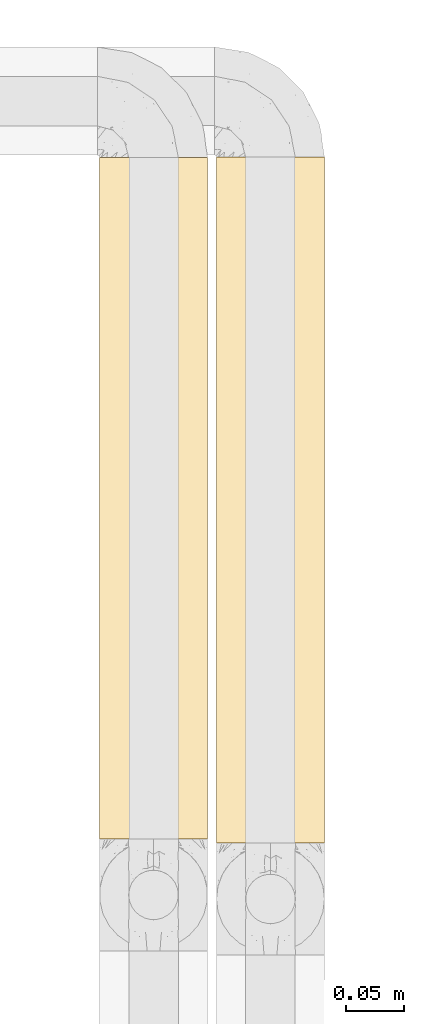
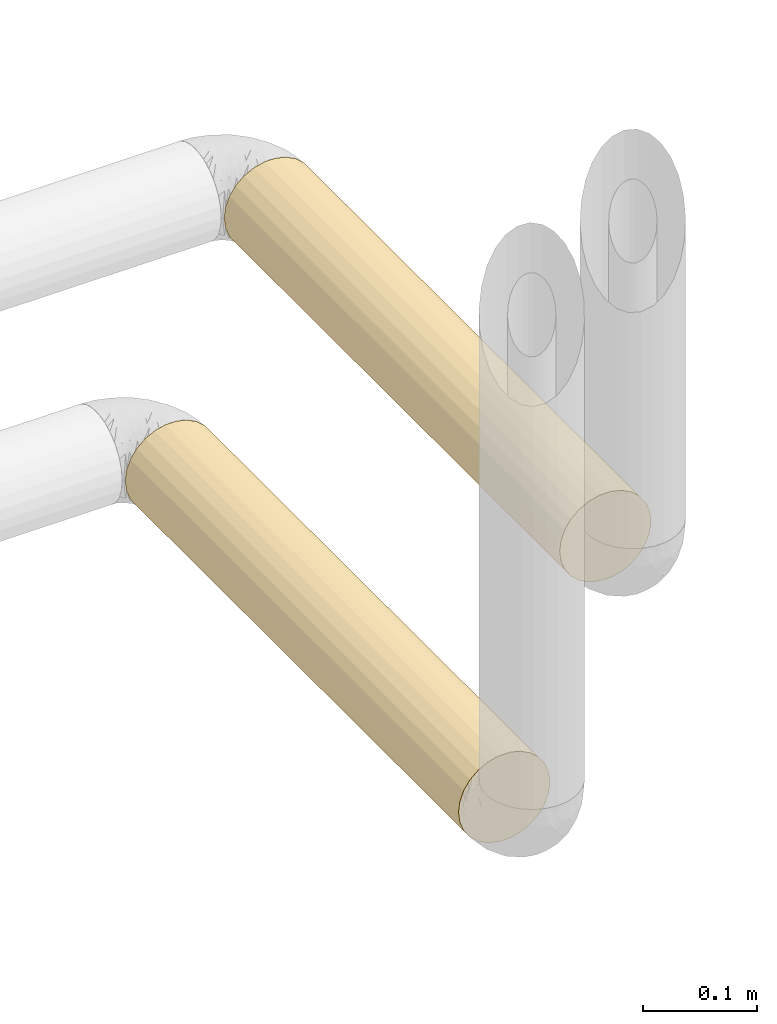
# One storey, part 19 of 824: 2 coverings.
"""IFC2X3 building model written with IfcOpenShell, lengths in millimetres."""

from ifc_helpers import new_model, entity, si_unit, converted_unit, derived_unit, direction, frame, origin, origin_2d_with_axis, place, context, subcontext, project, spatial, circle, extrude, element, save


model = new_model("IFC2X3")

# Units and contexts
model_context = context("Model", 3, precision=0.01, world=origin(), true_north=direction((6.12303176911189e-17, 1.0)))
body_context = subcontext(model_context, "Body", "Model", "MODEL_VIEW")
ifc_project = project(units=[si_unit("LENGTHUNIT", "METRE", prefix="MILLI"), si_unit("AREAUNIT", "SQUARE_METRE"), si_unit("VOLUMEUNIT", "CUBIC_METRE"), converted_unit("PLANEANGLEUNIT", "DEGREE", entity("IfcRatioMeasure", 0.0174532925199433), si_unit("PLANEANGLEUNIT", "RADIAN"), dimensions=[0, 0, 0, 0, 0, 0, 0]), si_unit("MASSUNIT", "GRAM", prefix="KILO"), derived_unit("MASSDENSITYUNIT", [(si_unit("MASSUNIT", "GRAM", prefix="KILO"), 1), (si_unit("LENGTHUNIT", "METRE"), -3)]), derived_unit("MOMENTOFINERTIAUNIT", [(si_unit("LENGTHUNIT", "METRE"), 4)]), si_unit("TIMEUNIT", "SECOND"), si_unit("FREQUENCYUNIT", "HERTZ"), si_unit("THERMODYNAMICTEMPERATUREUNIT", "DEGREE_CELSIUS"), derived_unit("THERMALTRANSMITTANCEUNIT", [(si_unit("MASSUNIT", "GRAM", prefix="KILO"), 1), (si_unit("THERMODYNAMICTEMPERATUREUNIT", "KELVIN"), -1), (si_unit("TIMEUNIT", "SECOND"), -3)]), derived_unit("VOLUMETRICFLOWRATEUNIT", [(si_unit("LENGTHUNIT", "METRE"), 3), (si_unit("TIMEUNIT", "SECOND"), -1)]), derived_unit("MASSFLOWRATEUNIT", [(si_unit("MASSUNIT", "GRAM", prefix="KILO"), 1), (si_unit("TIMEUNIT", "SECOND"), -1)]), derived_unit("ROTATIONALFREQUENCYUNIT", [(si_unit("TIMEUNIT", "SECOND"), -1)]), si_unit("ELECTRICCURRENTUNIT", "AMPERE"), si_unit("ELECTRICVOLTAGEUNIT", "VOLT"), si_unit("POWERUNIT", "WATT"), si_unit("FORCEUNIT", "NEWTON", prefix="KILO"), si_unit("ILLUMINANCEUNIT", "LUX"), si_unit("LUMINOUSFLUXUNIT", "LUMEN"), si_unit("LUMINOUSINTENSITYUNIT", "CANDELA"), derived_unit("USERDEFINED", [(si_unit("MASSUNIT", "GRAM", prefix="KILO"), -1), (si_unit("LENGTHUNIT", "METRE"), -2), (si_unit("TIMEUNIT", "SECOND"), 3), (si_unit("LUMINOUSFLUXUNIT", "LUMEN"), 1)]), derived_unit("LINEARVELOCITYUNIT", [(si_unit("LENGTHUNIT", "METRE"), 1), (si_unit("TIMEUNIT", "SECOND"), -1)]), si_unit("PRESSUREUNIT", "PASCAL"), derived_unit("USERDEFINED", [(si_unit("LENGTHUNIT", "METRE"), -2), (si_unit("MASSUNIT", "GRAM", prefix="KILO"), 1), (si_unit("TIMEUNIT", "SECOND"), -2)]), derived_unit("LINEARFORCEUNIT", [(si_unit("MASSUNIT", "GRAM", prefix="KILO"), 1), (si_unit("LENGTHUNIT", "METRE"), 1), (si_unit("TIMEUNIT", "SECOND"), -2), (si_unit("LENGTHUNIT", "METRE"), -1)]), derived_unit("PLANARFORCEUNIT", [(si_unit("MASSUNIT", "GRAM", prefix="KILO"), 1), (si_unit("LENGTHUNIT", "METRE"), 1), (si_unit("TIMEUNIT", "SECOND"), -2), (si_unit("LENGTHUNIT", "METRE"), -2)])], contexts=[model_context])

# Site, building, storey
site_placement = place(None, origin())
site = spatial("IfcSite", under=ifc_project, at=site_placement, CompositionType="ELEMENT")
building_placement = place(site_placement, origin())
building = spatial("IfcBuilding", under=site, at=building_placement, CompositionType="ELEMENT")
storey_placement = place(building_placement, frame((0.0, 0.0, 28200.0)))
storey = spatial("IfcBuildingStorey", under=building, at=storey_placement, CompositionType="ELEMENT", Elevation=28200.0)

# Coverings
covering_1_placement = place(storey_placement, frame((61004.89, 18185.33, 2041.63)))
element("IfcCovering", 1, at=covering_1_placement, inside=storey, PredefinedType="INSULATION", context=body_context, shape_type="SweptSolid", body=[
    extrude(circle(Radius=46.15, at=origin_2d_with_axis()), frame((47.75, 0.0, 47.75), z_axis=(0.0, 1.0, 0.0), x_axis=(-1.0, 0.0, 0.0)), (0.0, 0.0, 1.0), 582.616004091368),
])
covering_2_placement = place(storey_placement, frame((61104.89, 18181.83, 2287.0)))
element("IfcCovering", 2, at=covering_2_placement, inside=storey, PredefinedType="INSULATION", context=body_context, shape_type="SweptSolid", body=[
    extrude(circle(Radius=46.15, at=origin_2d_with_axis()), frame((47.75, 0.0, 47.75), z_axis=(0.0, 1.0, 0.0), x_axis=(-1.0, 0.0, 0.0)), (0.0, 0.0, 1.0), 586.263463574079),
])

save(model, "model.ifc")
